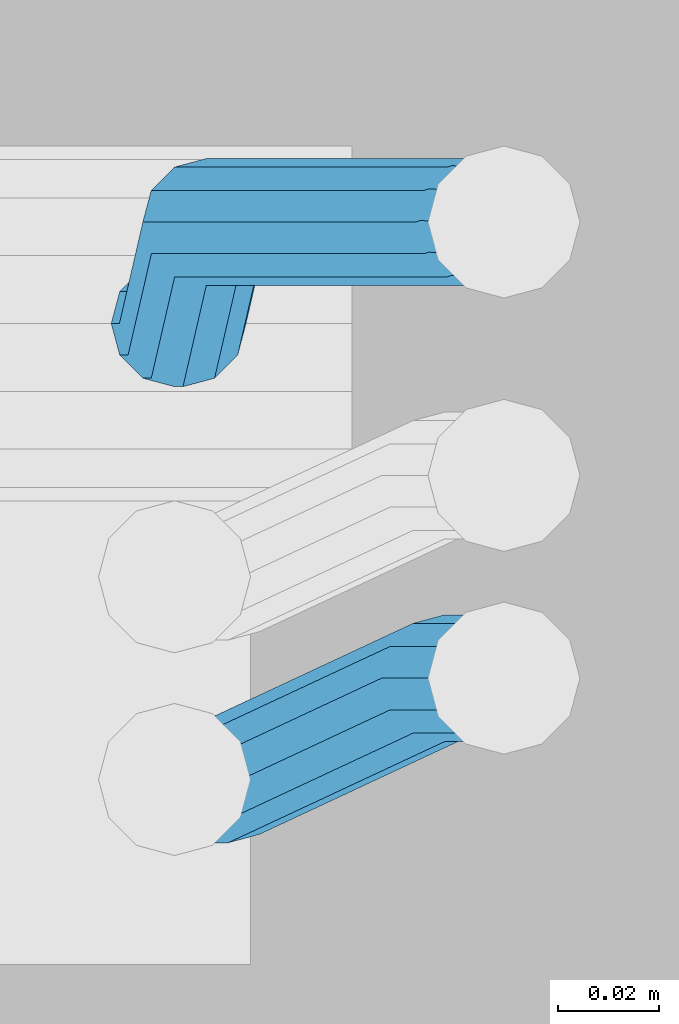
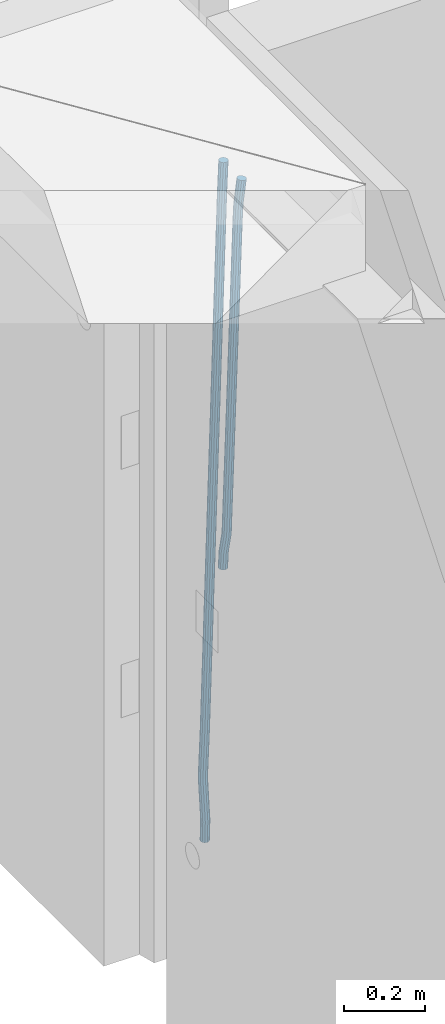
# One storey, part 116 of 334: 2 beams, 1 element without a shape of its own.
"""IFC2X3 building model written with IfcOpenShell, lengths in millimetres."""

from ifc_helpers import new_model, si_unit, frame, origin_with_axes, place, context, subcontext, project, spatial, faceted_brep, material, type_object, element, aggregate, save


model = new_model("IFC2X3")

# Units and contexts
model_context = context("Model", 3, precision=1e-05, world=origin_with_axes())
body_context = subcontext(model_context, "Body", "Model", "MODEL_VIEW")
ifc_project = project(units=[si_unit("LENGTHUNIT", "METRE", prefix="MILLI"), si_unit("AREAUNIT", "SQUARE_METRE"), si_unit("VOLUMEUNIT", "CUBIC_METRE"), si_unit("MASSUNIT", "GRAM", prefix="KILO"), si_unit("TIMEUNIT", "SECOND"), si_unit("PLANEANGLEUNIT", "RADIAN"), si_unit("SOLIDANGLEUNIT", "STERADIAN"), si_unit("THERMODYNAMICTEMPERATUREUNIT", "DEGREE_CELSIUS"), si_unit("LUMINOUSINTENSITYUNIT", "LUMEN")], contexts=[model_context])

# Site, building, storey
site_placement = place(None, origin_with_axes())
site = spatial("IfcSite", under=ifc_project, at=site_placement, CompositionType="ELEMENT")
building_placement = place(site_placement, origin_with_axes())
building = spatial("IfcBuilding", under=site, at=building_placement, CompositionType="ELEMENT")
storey_placement = place(building_placement, origin_with_axes())
storey = spatial("IfcBuildingStorey", under=building, at=storey_placement, Name="3", CompositionType="ELEMENT", Elevation=0.0)

# Assembly, beams
assembly_placement = place(storey_placement, origin_with_axes())
assembly = element("IfcElementAssembly", 1, at=assembly_placement, inside=storey, AssemblyPlace="NOTDEFINED", PredefinedType="REINFORCEMENT_UNIT")
ifc_material = material()
beam_type = type_object("IfcBeamType", Name="D25", PredefinedType="NOTDEFINED")
beam_1_placement = place(assembly_placement, frame((17644.9989431251, 20116.4982803956, 89267.5035525011), z_axis=(0.0, 1.0, 0.0), x_axis=(0.0467115440025518, 0.0, 0.998908420055061)))
beam_1 = element("IfcBeam", 2, at=beam_1_placement, type_object=beam_type, material=ifc_material, Name="JM25", ObjectType="D25", context=body_context, shape_type="Brep", body=[
    faceted_brep([(-7.41420080885291e-08, -12.5, -3.63797880709171e-12), (-6.42030499875546e-08, -10.8253175473074, -6.25000000000364), (48.7743672639481, -10.8253174221936, -6.25), (48.7743672682554, -12.4999998748863, 0.0), (-3.70782800018787e-08, -6.25000000000364, -10.8253175473074), (48.7743672522192, -6.24999987488263, -10.8253175473037), (-1.45519152283669e-11, -3.63797880709171e-12, -12.5), (48.7743672361976, 1.25113729154691e-07, -12.5), (3.70637280866504e-08, 6.25, -10.8253175473074), (48.7743672201614, 6.25000012511737, -10.8253175473037), (6.42030499875546e-08, 10.8253175473001, -6.25000000000364), (48.774367208418, 10.8253176724174, -6.25), (7.41420080885291e-08, 12.4999999999927, 0.0), (48.7743672041252, 12.5000001251174, 0.0), (6.42176019027829e-08, 10.8253175473001, 6.24999999999636), (48.774367208418, 10.8253176724174, 6.25), (3.70928319171071e-08, 6.24999999999636, 10.8253175473037), (48.7743672201614, 6.25000012511737, 10.8253175473037), (1.45519152283669e-11, -3.63797880709171e-12, 12.4999999999964), (48.7743672361976, 1.25113729154691e-07, 12.5), (-3.7049176171422e-08, -6.25000000000364, 10.8253175473001), (48.7743672522192, -6.24999987488263, 10.8253175473037), (-6.41884980723262e-08, -10.8253175473074, 6.25), (48.7743672639481, -10.8253174221936, 6.25), (50.6284132863948, -10.8253174174351, -6.25), (50.7256294211547, -12.4999998698804, 0.0), (50.362813866901, -6.2499998708081, -10.8253175473037), (49.9999983126327, 1.28262399812229e-07, -12.5), (49.6371827583935, 6.25000012732926, -10.8253175473037), (49.3715833388851, 10.8253176739527, -6.25), (49.2743672041252, 12.5000001264016, 0.0), (49.3715833388851, 10.8253176739527, 6.25), (49.6371827583935, 6.25000012732926, 10.8253175473037), (49.9999983126327, 1.28262399812229e-07, 12.5), (50.362813866901, -6.2499998708081, 10.8253175473037), (50.6284132863948, -10.8253174174351, 6.25), (52.4700055286376, -10.6107838149001, -6.25), (52.6637847850943, -12.2742172873113, 0.0), (51.9405907545442, -6.0661990532717, -10.8253175473037), (51.2173967239651, 0.141819180764287, -12.5), (50.494202693415, 6.34983741480755, -10.8253175473037), (49.9647879192926, 10.8944221764359, -6.25), (49.7710086628358, 12.5578556488472, 0.0), (49.9647879192926, 10.8944221764359, 6.25), (50.494202693415, 6.34983741480755, 10.8253175473037), (51.2173967239651, 0.141819180764287, 12.5), (51.9405907545442, -6.0661990532717, 10.8253175473037), (52.4700055286376, -10.6107838149037, 6.25), (100.1682419055, -5.05424733003747, -6.25), (100.362021161956, -6.71768080244692, 0.0), (99.6388271314063, -0.509662568409112, -10.8253175473037), (98.9156331008271, 5.69835566563052, -12.5), (98.192439070277, 11.9063738996665, -10.8253175473037), (97.6630242961546, 16.4509586612985, -6.25), (97.4692450396979, 18.1143921337098, 0.0), (97.6630242961546, 16.4509586612985, 6.25), (98.192439070277, 11.9063738996665, 10.8253175473037), (98.9156331008271, 5.69835566563052, 12.5), (99.6388271314063, -0.509662568409112, 10.8253175473037), (100.1682419055, -5.05424733003747, 6.25), (100.829389846811, -4.97722786481609, -6.25), (100.858662620667, -6.65982528000313, 0.0), (100.613505361369, -0.39611884945225, -10.8253175473037), (100.268855237926, 5.8559973049887, -12.5), (99.8877881987282, 12.1038711239344, -10.8253175473037), (99.5724108491268, 16.6733898631865, -6.25), (99.4072282953421, 18.3401546667665, 0.0), (99.4365010692127, 16.6575572515831, 6.25), (99.6523855546402, 12.0764482362174, 10.8253175473037), (99.9970356780832, 5.82433208178009, 12.5), (100.37810271731, -0.423541737165579, 10.8253175473037), (100.693480066882, -4.99306047642312, 6.25), (101.494850382805, -4.9772278650471, -6.23547852116099), (101.358543616545, -6.65982528017412, 0.0109082521194068), (101.594541309358, -0.396118849792401, -10.8039096771354), (101.63090429295, 5.85599730451395, -12.4702777768798), (101.594195901474, 12.1038711233377, -10.7880808337759), (101.49425211882, 16.6733898625134, -6.2080621602363), (101.357852800793, 18.340154666088, 0.0425659388420172), (101.221546034547, 16.6575572509591, 6.28895271212241), (101.121855107995, 12.0764482357044, 10.8573838680968), (101.085492124403, 5.82433208139992, 12.5237519678412), (101.122200515863, -0.423541737425694, 10.8415550247373), (101.222144298532, -4.99306047660866, 6.26153635119772), (1016.15234243186, -4.97722818425427, 13.7239010304511), (1016.01603566563, -6.65982559938311, 19.9702878037351), (1016.25203335841, -0.396119168995938, 9.15546987447669), (1016.28839634202, 5.85599698530859, 7.48910177473226), (1016.25168795056, 12.1038708041378, 9.17129871783618), (1016.15174416787, 16.6733895433135, 13.7513173913758), (1016.01534484986, 18.3401543468826, 20.0019454904541), (1015.8790380836, 16.6575569317556, 26.2483322637381), (1015.77934715705, 12.0764479165045, 30.8167634197125), (1015.74298417347, 5.82433176219456, 32.4831315194569), (1015.77969256493, -0.423542056632868, 30.8009345763494), (1015.8796363476, -4.99306079580856, 26.2209159028134), (1016.72024271244, -4.97722818445254, 13.7362935788587), (1016.65208128402, -6.65982559960139, 19.984167399125), (1016.77009392806, -0.396119169179656, 9.16677483576495), (1016.7882773379, 5.85599698513579, 7.50001002685531), (1016.76992071191, 12.1038708039559, 9.18260743664359), (1016.71994269331, 16.6733895431171, 13.7637164479929), (1016.65173485172, 18.3401543466607, 20.015832600875), (1016.58357342328, 16.65755693151, 26.2637064211413), (1016.53372220766, 12.0764479162353, 30.833225164235), (1016.51553879784, 5.82433176192717, 32.4999899731447), (1016.53389542381, -0.423542056894803, 30.8173925633564), (1016.58387344243, -4.99306079605594, 26.2362835520071), (1017.28827819017, -4.97722813975997, 13.7362935788587), (1017.28827832255, -6.6598255495519, 19.984167399125), (1017.28827782976, -0.396119128414284, 9.16677483576495), (1017.28827733788, 5.85599702447144, 7.50001002685531), (1017.28827684635, 12.103870844734, 9.18260743664359), (1017.28827648686, 16.6733895878278, 13.7637164479929), (1017.28827635571, 18.3401543967448, 20.015832600875), (1017.28827648809, 16.657556986951, 26.2637064211413), (1017.2882768485, 12.0764479756035, 30.833225164235), (1017.28827734038, 5.8243318227178, 32.4999899731447), (1017.28827783192, -0.423541997544817, 30.8173925633564), (1017.28827819142, -4.99306074063679, 26.2362835520071), (1065.6667756622, -4.97722433367016, 13.7362935788587), (1065.66677579457, -6.65982174345845, 19.984167399125), (1065.6667753018, -0.3961153223172, 9.16677483576495), (1065.66677480991, 5.85600083056488, 7.50001002685531), (1065.66677431838, 12.1038746508275, 9.18260743664359), (1065.66677395887, 16.6733933939249, 13.7637164479929), (1065.66677382775, 18.3401582028346, 20.015832600875), (1065.66677396011, 16.6575607930445, 26.2637064211413), (1065.66677432053, 12.0764517816933, 30.833225164235), (1065.6667748124, 5.82433562881488, 32.4999899731447), (1065.66677530395, -0.423538191451371, 30.8173925633564), (1065.66677566344, -4.99305693454517, 26.2362835520071), (1067.07165110651, -4.97722422314291, 13.7362935788587), (1067.13694763639, -6.65982162779255, 19.984167399125), (1066.89387208481, -0.396115225779795, 9.16677483576495), (1066.6512463166, 5.85600090801745, 7.50001002685531), (1066.40878518049, 12.1038747092061, 9.18260743664359), (1066.23145594214, 16.6733934383519, 13.7637164479929), (1066.16677382775, 18.340158242172, 20.015832600875), (1066.23207035761, 16.6575608375188, 26.2637064211413), (1066.40984937931, 12.0764518401556, 30.833225164235), (1066.65247514757, 5.82433570636204, 32.4999899731447), (1066.89493628364, -0.423538094826654, 30.8173925633564), (1067.07226552199, -4.99305682397062, 26.2362835520071), (1068.47230333716, -4.86837412698696, 13.736334784764), (1068.60269804588, -6.54588751704068, 19.9842150143704), (1068.11728165975, -0.301059828409052, 9.16679859123906), (1067.63276078545, 5.93224720081525, 7.50000996663584), (1067.14856769117, 12.161337376032, 9.18258357686864), (1066.79444152558, 16.7171310152116, 13.7636751818718), (1066.66527010873, 18.3789068918468, 20.0157849856296), (1066.79566481744, 16.7013935018003, 26.263665215236), (1067.15068649485, 12.134079203217, 30.8332014087609), (1067.63520736917, 5.90077217399266, 32.4999900333642), (1068.11940046342, -0.328318001224034, 30.8174164231314), (1068.47352662902, -4.88411164040008, 26.2363248181282), (1142.62319484423, 0.89544508106701, 13.736334784764), (1142.75358955294, -0.782068308983071, 19.9842150143704), (1142.26817316683, 5.4627593796431, 9.16679859123906), (1141.78365229251, 11.6960664088729, 7.50000996663584), (1141.29945919824, 17.9251565840896, 9.18258357686864), (1140.94533303265, 22.4809502232638, 13.7636751818718), (1140.81616161579, 24.1427260999008, 20.0157849856296), (1140.94655632452, 22.4652127098525, 26.263665215236), (1141.30157800192, 17.8978984112746, 30.8332014087609), (1141.78609887623, 11.6645913820466, 32.4999900333642), (1142.27029197049, 5.43550120682994, 30.8174164231314), (1142.6244181361, 0.879707567652076, 26.2363248181282)], [[[0, 1, 2, 3]], [[1, 4, 5, 2]], [[4, 6, 7, 5]], [[6, 8, 9, 7]], [[8, 10, 11, 9]], [[10, 12, 13, 11]], [[12, 14, 15, 13]], [[14, 16, 17, 15]], [[16, 18, 19, 17]], [[18, 20, 21, 19]], [[20, 22, 23, 21]], [[22, 0, 3, 23]], [[22, 20, 18, 16, 14, 12, 10, 8, 6, 4, 1, 0]], [[3, 2, 24, 25]], [[2, 5, 26, 24]], [[5, 7, 27, 26]], [[7, 9, 28, 27]], [[9, 11, 29, 28]], [[11, 13, 30, 29]], [[13, 15, 31, 30]], [[15, 17, 32, 31]], [[17, 19, 33, 32]], [[19, 21, 34, 33]], [[21, 23, 35, 34]], [[23, 3, 25, 35]], [[25, 24, 36, 37]], [[24, 26, 38, 36]], [[26, 27, 39, 38]], [[27, 28, 40, 39]], [[28, 29, 41, 40]], [[29, 30, 42, 41]], [[30, 31, 43, 42]], [[31, 32, 44, 43]], [[32, 33, 45, 44]], [[33, 34, 46, 45]], [[34, 35, 47, 46]], [[35, 25, 37, 47]], [[37, 36, 48, 49]], [[36, 38, 50, 48]], [[38, 39, 51, 50]], [[39, 40, 52, 51]], [[40, 41, 53, 52]], [[41, 42, 54, 53]], [[42, 43, 55, 54]], [[43, 44, 56, 55]], [[44, 45, 57, 56]], [[45, 46, 58, 57]], [[46, 47, 59, 58]], [[47, 37, 49, 59]], [[49, 48, 60, 61]], [[48, 50, 62, 60]], [[50, 51, 63, 62]], [[51, 52, 64, 63]], [[52, 53, 65, 64]], [[53, 54, 66, 65]], [[54, 55, 67, 66]], [[55, 56, 68, 67]], [[56, 57, 69, 68]], [[57, 58, 70, 69]], [[58, 59, 71, 70]], [[59, 49, 61, 71]], [[61, 60, 72, 73]], [[60, 62, 74, 72]], [[62, 63, 75, 74]], [[63, 64, 76, 75]], [[64, 65, 77, 76]], [[65, 66, 78, 77]], [[66, 67, 79, 78]], [[67, 68, 80, 79]], [[68, 69, 81, 80]], [[69, 70, 82, 81]], [[70, 71, 83, 82]], [[71, 61, 73, 83]], [[73, 72, 84, 85]], [[72, 74, 86, 84]], [[74, 75, 87, 86]], [[75, 76, 88, 87]], [[76, 77, 89, 88]], [[77, 78, 90, 89]], [[78, 79, 91, 90]], [[79, 80, 92, 91]], [[80, 81, 93, 92]], [[81, 82, 94, 93]], [[82, 83, 95, 94]], [[83, 73, 85, 95]], [[85, 84, 96, 97]], [[84, 86, 98, 96]], [[86, 87, 99, 98]], [[87, 88, 100, 99]], [[88, 89, 101, 100]], [[89, 90, 102, 101]], [[90, 91, 103, 102]], [[91, 92, 104, 103]], [[92, 93, 105, 104]], [[93, 94, 106, 105]], [[94, 95, 107, 106]], [[95, 85, 97, 107]], [[97, 96, 108, 109]], [[96, 98, 110, 108]], [[98, 99, 111, 110]], [[99, 100, 112, 111]], [[100, 101, 113, 112]], [[101, 102, 114, 113]], [[102, 103, 115, 114]], [[103, 104, 116, 115]], [[104, 105, 117, 116]], [[105, 106, 118, 117]], [[106, 107, 119, 118]], [[107, 97, 109, 119]], [[109, 108, 120, 121]], [[108, 110, 122, 120]], [[110, 111, 123, 122]], [[111, 112, 124, 123]], [[112, 113, 125, 124]], [[113, 114, 126, 125]], [[114, 115, 127, 126]], [[115, 116, 128, 127]], [[116, 117, 129, 128]], [[117, 118, 130, 129]], [[118, 119, 131, 130]], [[119, 109, 121, 131]], [[121, 120, 132, 133]], [[120, 122, 134, 132]], [[122, 123, 135, 134]], [[123, 124, 136, 135]], [[124, 125, 137, 136]], [[125, 126, 138, 137]], [[126, 127, 139, 138]], [[127, 128, 140, 139]], [[128, 129, 141, 140]], [[129, 130, 142, 141]], [[130, 131, 143, 142]], [[131, 121, 133, 143]], [[133, 132, 144, 145]], [[132, 134, 146, 144]], [[134, 135, 147, 146]], [[135, 136, 148, 147]], [[136, 137, 149, 148]], [[137, 138, 150, 149]], [[138, 139, 151, 150]], [[139, 140, 152, 151]], [[140, 141, 153, 152]], [[141, 142, 154, 153]], [[142, 143, 155, 154]], [[143, 133, 145, 155]], [[145, 144, 156, 157]], [[144, 146, 158, 156]], [[146, 147, 159, 158]], [[147, 148, 160, 159]], [[148, 149, 161, 160]], [[149, 150, 162, 161]], [[150, 151, 163, 162]], [[151, 152, 164, 163]], [[152, 153, 165, 164]], [[153, 154, 166, 165]], [[154, 155, 167, 166]], [[155, 145, 157, 167]], [[158, 159, 160, 161, 162, 163, 164, 165, 166, 167, 157, 156]]]),
])
beam_2_placement = place(assembly_placement, frame((17645.0, 20206.4982799665, 88390.0), z_axis=(0.999642804629538, 0.000205762999925497, -0.0267249099901003), x_axis=(0.0267249109941254, -4.30000210532798e-08, 0.999642825779465)))
beam_2 = element("IfcBeam", 3, at=beam_2_placement, type_object=beam_type, material=ifc_material, Name="JM25", ObjectType="D25", context=body_context, shape_type="Brep", body=[
    faceted_brep([(-7.41420080885291e-08, -12.5, -3.63797880709171e-12), (-6.42030499875546e-08, -10.8253175473074, -6.25000000000364), (59.4220778053423, -10.8253175324608, -6.25000005319089), (59.4220778086747, -12.4999999851534, -5.3194526117295e-08), (-3.70782800018787e-08, -6.25000000000364, -10.8253175473074), (59.4220778020681, -6.24999998515341, -10.8253176004946), (-1.45519152283669e-11, -3.63797880709171e-12, -12.5), (59.4220777997252, 1.48465915117413e-08, -12.5000000531927), (3.70637280866504e-08, 6.25, -10.8253175473074), (59.422077798954, 6.25000001485023, -10.8253176004982), (6.42030499875546e-08, 10.8253175473001, -6.25000000000364), (59.4220777999435, 10.8253175621539, -6.25000005319089), (7.41420080885291e-08, 12.4999999999927, 0.0), (59.4220778024173, 12.5000000148466, -5.31908881384879e-08), (6.42176019027829e-08, 10.8253175473001, 6.24999999999636), (59.4220778057497, 10.8253175621576, 6.24999994680911), (3.70928319171071e-08, 6.24999999999636, 10.8253175473037), (59.4220778090239, 6.25000001485023, 10.8253174941128), (1.45519152283669e-11, -3.63797880709171e-12, 12.4999999999964), (59.4220778113668, 1.48465915117413e-08, 12.4999999468128), (-3.7049176171422e-08, -6.25000000000364, 10.8253175473001), (59.4220778121526, -6.24999998515705, 10.8253174941183), (-6.41884980723262e-08, -10.8253175473074, 6.25), (59.422077811163, -10.8253175324571, 6.24999994680547), (60.1059015733626, -10.8253175322861, -6.25000005380571), (59.9220778086747, -12.4999999850261, -5.36383595317602e-08), (60.5270973313018, -6.24999998487692, -10.8253176014878), (61.0728060192778, 1.52613210957497e-08, -12.5000000546715), (61.5968054350378, 6.25000001539229, -10.8253176024446), (61.9586903583258, 10.825317562787, -6.25000005546281), (62.0614940161613, 12.5000000155051, -5.55555743630975e-08), (61.8776702514588, 10.8253175627651, 6.24999994460995), (61.4564744935342, 6.25000001535955, 10.8253174922938), (60.9107658055436, 1.52213033288717e-08, 12.4999999454776), (60.3867663897981, -6.2499999849133, 10.8253174932506), (60.0248814664956, -10.825317532308, 6.24999994626887), (60.7797257564671, -10.9415004936782, -6.24120031120765), (60.4147662867617, -12.5849509379113, 0.00643416450657242), (61.6159581115353, -6.43774490879878, -10.8110977280703), (62.6993955677171, -0.280461855141766, -12.4787577637399), (63.739731933616, 5.88050964549984, -10.7973322583985), (64.4582099200925, 10.3943422549237, -6.21735781835014), (64.6623139309086, 12.0515581706859, 0.03396510384664), (64.2973544612178, 10.4081077264564, 6.28159957956086), (63.461122106135, 5.90435214157333, 10.8514969964235), (62.3776846499532, -0.252930912083684, 12.5191570320894), (61.3373482840689, -6.41390241272165, 10.8377315267553), (60.6188702975924, -10.9277350221564, 6.25775708670699), (173.678050556482, -30.407797550004, -4.76681541592006), (173.313091086762, -32.0512479942336, 1.4808190597978), (174.514282911536, -25.9040419651246, -9.33671283278272), (175.597720367718, -19.7467589114676, -11.0043728684504), (176.638056733602, -13.585787410826, -9.32294736311087), (177.356534720093, -9.0719548013949, -4.74297292306073), (177.560638730924, -7.41473888563996, 1.50834999913423), (177.195679261218, -9.05818932986585, 7.75598447485027), (176.35944690615, -13.5619449147489, 12.3258818917166), (175.276009449968, -19.7192279684059, 13.9935419273806), (174.235673084069, -25.8801994690475, 12.3121164220465), (173.517195097593, -30.3940320784823, 7.73214198199094), (176.138237106381, -30.8319909317906, -4.73468684452382), (175.913853754129, -32.499679968274, 1.51478347157899), (176.589132212815, -26.2617942428296, -9.30961653639861), (177.145722093832, -20.0136704134529, -10.98415688768), (177.658868940271, -13.7617991779516, -9.30961616354944), (177.991075469021, -9.18136438506554, -4.73468619872801), (178.053327209011, -7.49968983852159, 1.5147842172828), (177.828943856759, -9.16737887500858, 7.76425453338925), (177.37804875031, -13.7375755639696, 12.3391842252604), (176.821458869294, -19.9856993933463, 14.0137245765418), (176.308312022869, -26.237570628844, 12.3391838524112), (175.976105494119, -30.8180054217337, 7.76425388758798), (178.634722048839, -30.8318743800774, -4.70223538057326), (178.552989161486, -32.4996730848652, 1.54907076560085), (178.694593853957, -26.2615981169292, -9.28219734144659), (178.71656197503, -20.0134461293128, -10.9636180082289), (178.694740071747, -13.7616056964944, -9.29596207112627), (178.634975305482, -9.18125241366579, -4.72607659172718), (178.553281597095, -7.49968824400275, 1.52154130624513), (178.471548709742, -9.16748694879061, 7.7728474524265), (178.411676904623, -13.7377632119424, 12.3528094132944), (178.389708783536, -19.9859151995588, 14.0342300800785), (178.411530686833, -26.23775563237, 12.3665741429741), (178.471295453099, -30.8181089152022, 7.79668866358043), (319.488626215083, -30.8314939674237, -2.86053540860667), (319.406893327759, -32.499292672208, 3.39077073757289), (319.548498020216, -26.261217704272, -7.44049736947818), (319.570466141289, -20.0130657166519, -9.12191803626411), (319.548644237992, -13.7612252838408, -7.45426209915786), (319.488879471741, -9.18087200101581, -2.88437661976423), (319.407185763353, -7.4993078313455, 3.36324127821172), (319.325452876015, -9.167106536137, 9.61454742438946), (319.265581070882, -13.7373827992851, 14.1945093852592), (319.243612949809, -19.9855347868979, 15.8759300520433), (319.265434853078, -26.2373752197163, 14.2082741149388), (319.325199619343, -30.8177285025449, 9.63838863554338), (320.017443228702, -30.8314925392151, -2.85362099409576), (319.964532372032, -32.4992911661575, 3.39806200733256), (320.056202037245, -26.2612163330814, -7.43385901266629), (320.070423406214, -20.013064366387, -9.11538097016819), (320.056296731302, -13.7612239127957, -7.44762441603234), (320.01760724363, -9.18087057304729, -2.87746337211138), (319.964721760145, -7.4993063255788, 3.37053120060227), (319.91181090349, -9.16710495252482, 9.62221420203059), (319.873052094961, -13.7373811586476, 14.2024522205975), (319.858830725978, -19.9855331253457, 15.8839741781048), (319.87295740089, -26.2373735789442, 14.2162176239653), (319.911646888577, -30.8177269186926, 9.64605658004257), (320.546301518712, -30.8314921215424, -2.85158332608989), (320.522214942423, -32.4992907257256, 3.40021073403295), (320.563945682734, -26.2612159320888, -7.431902698474), (320.570419694937, -20.0130639715098, -9.1134545062032), (320.563988849026, -13.7612235118395, -7.44566830037184), (320.546376284925, -9.1808701554437, -2.87542604797454), (320.522301275021, -7.49930588522329, 3.37267953023547), (320.498214698731, -9.16710448940648, 9.62447359036014), (320.480570534695, -13.7373806788601, 14.2047929627461), (320.474096522506, -19.9855326394354, 15.8863447704753), (320.480527368418, -26.2373730991094, 14.2185585646439), (320.498139932504, -30.8177264555052, 9.64831631225024), (1894.35323904471, -30.8302491939103, 3.21222639639745), (1894.32915246842, -32.4980477980898, 9.46402045652394), (1894.37088320871, -26.2599730044531, -1.36809297598302), (1894.37735722095, -20.0118210438777, -3.04964478371585), (1894.37092637502, -13.7599805842037, -1.38185857788449), (1894.35331381093, -9.1796272278043, 3.18838367451281), (1894.32923880102, -7.4980629575839, 9.43648925272464), (1894.30515222471, -9.16586156176709, 15.6882833128511), (1894.2875080607, -13.7361377512207, 20.2686026852371), (1894.28103404849, -19.9842897117996, 21.9501544929644), (1894.2874648944, -26.2361301714736, 20.2823682871331), (1894.30507745848, -30.8164835278658, 15.7121260347358), (1894.91223858956, -30.8302487524343, 3.21438019734705), (1894.84772318714, -32.4980473885444, 9.46601848696628), (1894.98133310449, -26.2599725223481, -1.36574093906893), (1895.03649291246, -20.0118205233157, -3.04710516254454), (1895.06293798747, -13.7599800376811, -1.37919228721876), (1895.05358239301, -9.17962667476604, 3.19108177892304), (1895.01093295308, -7.49806241920669, 9.43911579066662), (1894.94641755069, -9.16586105532406, 15.6907540802767), (1894.87732303573, -13.7361372854102, 20.2708752166945), (1894.82216322777, -19.984289284439, 21.9522394401702), (1894.79571815276, -26.2361297700772, 20.284326564848), (1894.80507374721, -30.8164831329887, 15.7140524987026), (1895.47114527243, -30.837537004496, 3.22181869265842), (1895.36620776, -32.5048085284143, 9.47291900396158), (1895.59168159126, -26.267931585553, -1.35761780421126), (1895.69551910722, -20.0204143533228, -3.03833417552232), (1895.75483464175, -13.7690025048832, -1.36998382688762), (1895.75373464527, -9.18875679657504, 3.20040011310266), (1895.69251386097, -7.50695036707475, 9.44818695861068), (1895.58757634854, -9.17422189099307, 15.699287269912), (1895.4670400297, -13.7438273099324, 20.2787237667835), (1895.36320251375, -19.9913445421626, 21.9594401380946), (1895.30388697921, -26.2427563905985, 20.2910897894599), (1895.30498697569, -30.823002098914, 15.720705849466), (1917.25744196717, -31.1216345590001, 3.51177275974987), (1917.15250445475, -32.788906082922, 9.7628730710494), (1917.37797828601, -26.5520291400608, -1.0676637371198), (1917.48181580196, -20.3045119078306, -2.7483801084345), (1917.5411313365, -14.0531000593946, -1.08002975979252), (1917.54003134, -9.47285435107915, 3.49035418019412), (1917.47881055571, -7.7910479215825, 9.73814102570577), (1917.37387304328, -9.45831944550082, 15.9892413370071), (1917.25333672446, -14.0279248644365, 20.5686778338786), (1917.14949920849, -20.2754420966667, 22.2493942051933), (1917.09018367396, -26.5268539451099, 20.5810438565477), (1917.09128367042, -31.1070996534218, 16.0106599165647), (1917.94316974688, -31.1305765828838, 3.52089911846269), (1917.85264237775, -32.7980360178735, 9.77219121452072), (1918.02633208608, -26.5604837999635, -1.05903478912296), (1918.0798461137, -20.3123103396429, -2.7404209163069), (1918.08937278928, -14.0602492347753, -1.07273320814602), (1918.05235944779, -9.47953520944429, 3.49717276072806), (1917.9787237842, -7.79756688750422, 9.74479437647096), (1917.88819641506, -9.46502632249758, 15.9960864725308), (1917.80503407588, -14.0351191054142, 20.5760203801128), (1917.75152004823, -20.2832925657385, 22.257406507304), (1917.74199337266, -26.5353536706025, 20.5897187991395), (1917.77900671415, -31.1160676959298, 16.0198128302654), (1918.62895550129, -31.1285475281402, 3.52982218347461), (1918.55283939735, -32.795947999115, 9.78130547352521), (1918.67474087057, -26.5585779185749, -1.05060823136955), (1918.67792735249, -20.3105588367471, -2.73266314035027), (1918.63766113177, -14.0586419499232, -1.06563728897891), (1918.56473150974, -9.47802333907384, 3.50379109209644), (1918.47867991975, -7.79607606181162, 9.75124735830832), (1918.40256381579, -9.46347653279008, 16.0027306483644), (1918.35677844651, -14.0334461423481, 20.5831610632049), (1918.35359196461, -20.2814652241759, 22.2652159721838), (1918.39385818531, -26.5333821109998, 20.5981901208143), (1918.46678780734, -31.1140007218564, 16.0287617397316), (2018.62971518922, -30.8303462840922, 4.82693655916046), (2018.5535990853, -32.4977467550671, 11.0784198492183), (2018.67550055851, -26.2603766745233, 0.246506144323575), (2018.67868704045, -20.0123575926991, -1.43554876465714), (2018.63842081973, -13.7604407058789, 0.231477086710584), (2018.5654911977, -9.17982209502588, 4.80090546778956), (2018.47943960771, -7.49787481776366, 11.0483617339996), (2018.40332350375, -9.16527528874212, 17.2998450240593), (2018.35753813446, -13.7352448983038, 21.880275438898), (2018.35435165254, -19.9832639801316, 23.5623303478787), (2018.39461787326, -26.2351808669555, 21.8953044965092), (2018.46754749528, -30.8157994778048, 17.3258761154248)], [[[0, 1, 2, 3]], [[1, 4, 5, 2]], [[4, 6, 7, 5]], [[6, 8, 9, 7]], [[8, 10, 11, 9]], [[10, 12, 13, 11]], [[12, 14, 15, 13]], [[14, 16, 17, 15]], [[16, 18, 19, 17]], [[18, 20, 21, 19]], [[20, 22, 23, 21]], [[22, 0, 3, 23]], [[22, 20, 18, 16, 14, 12, 10, 8, 6, 4, 1, 0]], [[3, 2, 24, 25]], [[2, 5, 26, 24]], [[5, 7, 27, 26]], [[7, 9, 28, 27]], [[9, 11, 29, 28]], [[11, 13, 30, 29]], [[13, 15, 31, 30]], [[15, 17, 32, 31]], [[17, 19, 33, 32]], [[19, 21, 34, 33]], [[21, 23, 35, 34]], [[23, 3, 25, 35]], [[25, 24, 36, 37]], [[24, 26, 38, 36]], [[26, 27, 39, 38]], [[27, 28, 40, 39]], [[28, 29, 41, 40]], [[29, 30, 42, 41]], [[30, 31, 43, 42]], [[31, 32, 44, 43]], [[32, 33, 45, 44]], [[33, 34, 46, 45]], [[34, 35, 47, 46]], [[35, 25, 37, 47]], [[37, 36, 48, 49]], [[36, 38, 50, 48]], [[38, 39, 51, 50]], [[39, 40, 52, 51]], [[40, 41, 53, 52]], [[41, 42, 54, 53]], [[42, 43, 55, 54]], [[43, 44, 56, 55]], [[44, 45, 57, 56]], [[45, 46, 58, 57]], [[46, 47, 59, 58]], [[47, 37, 49, 59]], [[49, 48, 60, 61]], [[48, 50, 62, 60]], [[50, 51, 63, 62]], [[51, 52, 64, 63]], [[52, 53, 65, 64]], [[53, 54, 66, 65]], [[54, 55, 67, 66]], [[55, 56, 68, 67]], [[56, 57, 69, 68]], [[57, 58, 70, 69]], [[58, 59, 71, 70]], [[59, 49, 61, 71]], [[61, 60, 72, 73]], [[60, 62, 74, 72]], [[62, 63, 75, 74]], [[63, 64, 76, 75]], [[64, 65, 77, 76]], [[65, 66, 78, 77]], [[66, 67, 79, 78]], [[67, 68, 80, 79]], [[68, 69, 81, 80]], [[69, 70, 82, 81]], [[70, 71, 83, 82]], [[71, 61, 73, 83]], [[73, 72, 84, 85]], [[72, 74, 86, 84]], [[74, 75, 87, 86]], [[75, 76, 88, 87]], [[76, 77, 89, 88]], [[77, 78, 90, 89]], [[78, 79, 91, 90]], [[79, 80, 92, 91]], [[80, 81, 93, 92]], [[81, 82, 94, 93]], [[82, 83, 95, 94]], [[83, 73, 85, 95]], [[85, 84, 96, 97]], [[84, 86, 98, 96]], [[86, 87, 99, 98]], [[87, 88, 100, 99]], [[88, 89, 101, 100]], [[89, 90, 102, 101]], [[90, 91, 103, 102]], [[91, 92, 104, 103]], [[92, 93, 105, 104]], [[93, 94, 106, 105]], [[94, 95, 107, 106]], [[95, 85, 97, 107]], [[97, 96, 108, 109]], [[96, 98, 110, 108]], [[98, 99, 111, 110]], [[99, 100, 112, 111]], [[100, 101, 113, 112]], [[101, 102, 114, 113]], [[102, 103, 115, 114]], [[103, 104, 116, 115]], [[104, 105, 117, 116]], [[105, 106, 118, 117]], [[106, 107, 119, 118]], [[107, 97, 109, 119]], [[109, 108, 120, 121]], [[108, 110, 122, 120]], [[110, 111, 123, 122]], [[111, 112, 124, 123]], [[112, 113, 125, 124]], [[113, 114, 126, 125]], [[114, 115, 127, 126]], [[115, 116, 128, 127]], [[116, 117, 129, 128]], [[117, 118, 130, 129]], [[118, 119, 131, 130]], [[119, 109, 121, 131]], [[121, 120, 132, 133]], [[120, 122, 134, 132]], [[122, 123, 135, 134]], [[123, 124, 136, 135]], [[124, 125, 137, 136]], [[125, 126, 138, 137]], [[126, 127, 139, 138]], [[127, 128, 140, 139]], [[128, 129, 141, 140]], [[129, 130, 142, 141]], [[130, 131, 143, 142]], [[131, 121, 133, 143]], [[133, 132, 144, 145]], [[132, 134, 146, 144]], [[134, 135, 147, 146]], [[135, 136, 148, 147]], [[136, 137, 149, 148]], [[137, 138, 150, 149]], [[138, 139, 151, 150]], [[139, 140, 152, 151]], [[140, 141, 153, 152]], [[141, 142, 154, 153]], [[142, 143, 155, 154]], [[143, 133, 145, 155]], [[145, 144, 156, 157]], [[144, 146, 158, 156]], [[146, 147, 159, 158]], [[147, 148, 160, 159]], [[148, 149, 161, 160]], [[149, 150, 162, 161]], [[150, 151, 163, 162]], [[151, 152, 164, 163]], [[152, 153, 165, 164]], [[153, 154, 166, 165]], [[154, 155, 167, 166]], [[155, 145, 157, 167]], [[157, 156, 168, 169]], [[156, 158, 170, 168]], [[158, 159, 171, 170]], [[159, 160, 172, 171]], [[160, 161, 173, 172]], [[161, 162, 174, 173]], [[162, 163, 175, 174]], [[163, 164, 176, 175]], [[164, 165, 177, 176]], [[165, 166, 178, 177]], [[166, 167, 179, 178]], [[167, 157, 169, 179]], [[169, 168, 180, 181]], [[168, 170, 182, 180]], [[170, 171, 183, 182]], [[171, 172, 184, 183]], [[172, 173, 185, 184]], [[173, 174, 186, 185]], [[174, 175, 187, 186]], [[175, 176, 188, 187]], [[176, 177, 189, 188]], [[177, 178, 190, 189]], [[178, 179, 191, 190]], [[179, 169, 181, 191]], [[181, 180, 192, 193]], [[180, 182, 194, 192]], [[182, 183, 195, 194]], [[183, 184, 196, 195]], [[184, 185, 197, 196]], [[185, 186, 198, 197]], [[186, 187, 199, 198]], [[187, 188, 200, 199]], [[188, 189, 201, 200]], [[189, 190, 202, 201]], [[190, 191, 203, 202]], [[191, 181, 193, 203]], [[194, 195, 196, 197, 198, 199, 200, 201, 202, 203, 193, 192]]]),
])
aggregate(assembly, [beam_1, beam_2])

save(model, "model.ifc")
